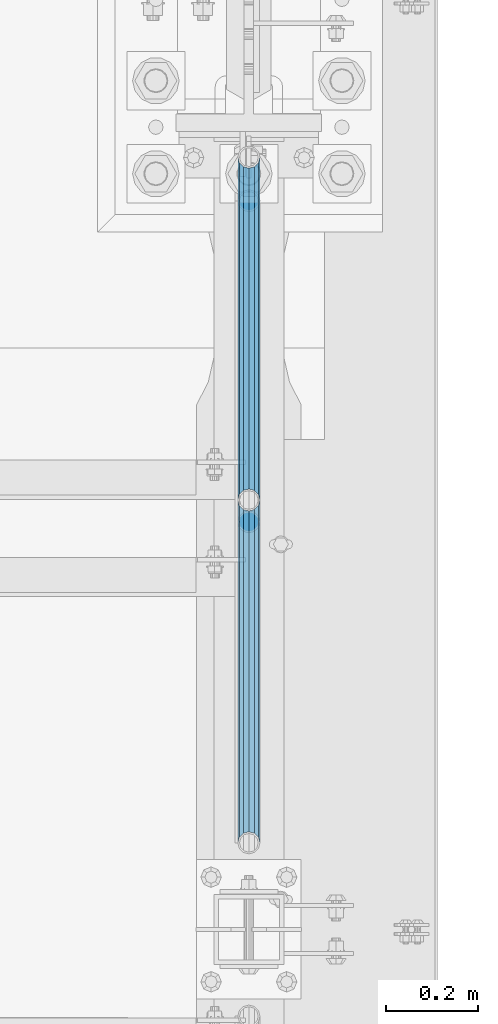
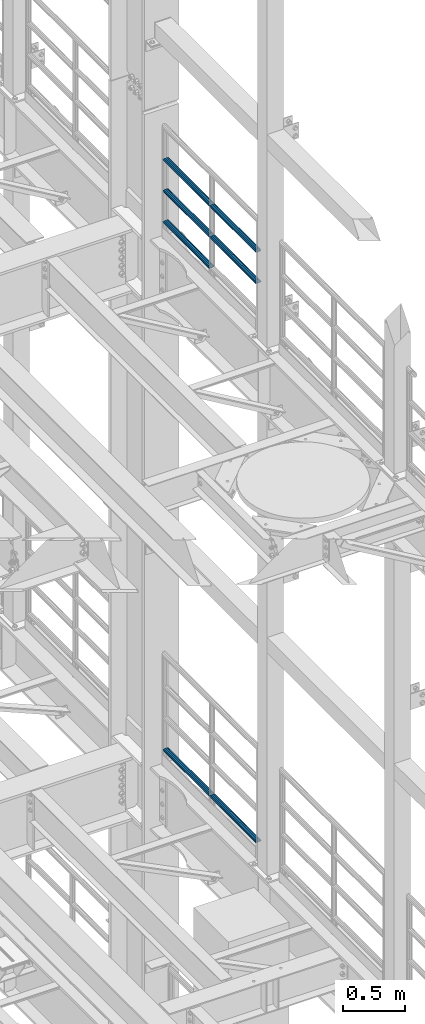
# One storey, part 1335 of 1876: 7 beams, 2 elements without a shape of their own.
"""IFC2X3 building model written with IfcOpenShell, lengths in millimetres."""

from ifc_helpers import new_model, si_unit, frame, origin_with_axes, place, context, subcontext, project, spatial, faceted_brep, material, type_object, element, aggregate, save


model = new_model("IFC2X3")

# Units and contexts
model_context = context("Model", 3, precision=1e-05, world=origin_with_axes())
body_context = subcontext(model_context, "Body", "Model", "MODEL_VIEW")
ifc_project = project(units=[si_unit("LENGTHUNIT", "METRE", prefix="MILLI"), si_unit("AREAUNIT", "SQUARE_METRE"), si_unit("VOLUMEUNIT", "CUBIC_METRE"), si_unit("MASSUNIT", "GRAM", prefix="KILO"), si_unit("TIMEUNIT", "SECOND"), si_unit("PLANEANGLEUNIT", "RADIAN"), si_unit("SOLIDANGLEUNIT", "STERADIAN"), si_unit("THERMODYNAMICTEMPERATUREUNIT", "DEGREE_CELSIUS"), si_unit("LUMINOUSINTENSITYUNIT", "LUMEN")], contexts=[model_context])

# Site, building, storey
site_placement = place(None, origin_with_axes())
site = spatial("IfcSite", under=ifc_project, at=site_placement, CompositionType="ELEMENT")
building_placement = place(site_placement, origin_with_axes())
building = spatial("IfcBuilding", under=site, at=building_placement, Name="Undefined", CompositionType="ELEMENT")
storey_placement = place(building_placement, origin_with_axes())
storey = spatial("IfcBuildingStorey", under=building, at=storey_placement, Name="Undefined", CompositionType="ELEMENT", Elevation=0.0)

# Assembly, beams
assembly_1_placement = place(storey_placement, origin_with_axes())
assembly_1 = element("IfcElementAssembly", 1, at=assembly_1_placement, inside=storey, Name="RAIL", AssemblyPlace="NOTDEFINED", PredefinedType="RIGID_FRAME")
ifc_material = material()
beam_type = type_object("IfcBeamType", Name="PIPE1-1/2SCH40", PredefinedType="NOTDEFINED")
beam_1_placement = place(assembly_1_placement, frame((7619.99999999999, 7275.195, 13471.525), z_axis=(0.0, 0.0, 1.0), x_axis=(0.0, -1.0, 0.0)))
beam_1 = element("IfcBeam", 2, at=beam_1_placement, type_object=beam_type, material=ifc_material, Name="RAIL", ObjectType="PIPE1-1/2SCH40", context=body_context, shape_type="Brep", body=[
    faceted_brep([(728.085307006683, -12.0649999999996, 20.8971929933177), (728.085307006683, -12.0649999999996, 15.8661214311796), (727.591878568821, -10.2235000000001, 17.7076214311819), (724.852500000002, 0.0, 20.4470000000001), (724.852500000002, 0.0, 24.130000000001), (727.591878568821, 10.2235000000001, 17.7076214311819), (728.085307006683, 12.0649999999996, 15.8661214311796), (728.085307006683, 12.0649999999996, 20.8971929933177), (748.982500000002, 24.1300000000001, 0.0), (736.917500000002, 20.8971929933186, 12.0649999999987), (736.917500000002, 20.8971929933186, -12.0649999999987), (733.727928437864, 17.7076214311801, 10.2235000000001), (736.467307006683, 20.4470000000001, 0.0), (733.727928437864, 17.7076214311801, -10.2235000000001), (728.085307006683, 12.0649999999996, -15.8661214311796), (728.085307006683, 12.0649999999996, -20.8971929933177), (727.591878568821, 10.2235000000001, -17.7076214311819), (724.852500000002, 0.0, -20.4470000000001), (724.852500000002, 0.0, -24.130000000001), (728.085307006683, -12.0649999999996, -15.8661214311796), (728.085307006683, -12.0649999999996, -20.8971929933177), (727.591878568821, -10.2235000000001, -17.7076214311819), (748.982500000002, -24.1300000000001, 0.0), (736.917500000002, -20.8971929933186, -12.0649999999987), (736.917500000002, -20.8971929933186, 12.0649999999987), (733.727928437864, -17.7076214311801, -10.2235000000001), (736.467307006683, -20.4470000000001, 0.0), (733.727928437864, -17.7076214311801, 10.2235000000001), (12.0650000000064, -20.8971929933177, -12.0649999999987), (20.8971929933249, -12.0650000000005, -20.8971929933177), (0.0, 24.1299999999992, 0.0), (12.0650000000064, 20.8971929933177, -12.0649999999987), (12.0650000000064, 20.8971929933177, 12.0649999999987), (20.8971929933249, 12.0650000000005, 20.8971929933177), (24.1300000000064, 0.0, 24.130000000001), (20.8971929933249, 12.0650000000005, -20.8971929933177), (24.1300000000063, 0.0, -24.130000000001), (24.1300000000063, 0.0, -20.4470000000001), (20.8971929933249, -12.0650000000005, -15.8661214311796), (21.3906214311868, -10.2235000000001, -17.7076214311819), (21.3906214311868, 10.2235000000001, -17.7076214311819), (20.8971929933249, 12.0650000000005, -15.8661214311796), (15.2545715621445, 17.7076214311801, -10.2235000000001), (12.5151929933249, 20.4470000000001, 0.0), (15.2545715621445, 17.7076214311801, 10.2235000000001), (20.8971929933249, 12.0650000000005, 15.8661214311796), (21.3906214311868, 10.2235000000001, 17.7076214311819), (24.1300000000064, 0.0, 20.4470000000001), (21.3906214311868, -10.2235000000001, 17.7076214311819), (20.8971929933249, -12.0650000000005, 15.8661214311796), (20.8971929933249, -12.0650000000005, 20.8971929933177), (12.0650000000064, -20.8971929933177, 12.0649999999987), (0.0, -24.1299999999992, 0.0), (15.2545715621445, -17.7076214311801, 10.2235000000001), (12.5151929933249, -20.4470000000001, 0.0), (15.2545715621445, -17.7076214311801, -10.2235000000001)], [[[0, 1, 2, 3, 4]], [[4, 3, 5, 6, 7]], [[8, 9, 10]], [[7, 6, 11, 12, 13, 14, 15, 10, 9]], [[16, 17, 18, 15, 14]], [[19, 20, 18, 17, 21]], [[22, 23, 24]], [[24, 23, 20, 19, 25, 26, 27, 1, 0]], [[28, 29, 20, 23]], [[30, 31, 32]], [[33, 34, 4, 7]], [[32, 33, 7, 9]], [[30, 32, 9, 8]], [[31, 30, 8, 10]], [[35, 31, 10, 15]], [[36, 35, 15, 18]], [[29, 36, 18, 20]], [[37, 36, 29, 38, 39]], [[40, 41, 35, 36, 37]], [[32, 31, 35, 41, 42, 43, 44, 45, 33]], [[33, 45, 46, 47, 34]], [[34, 47, 48, 49, 50]], [[34, 50, 0, 4]], [[50, 51, 24, 0]], [[51, 52, 22, 24]], [[52, 28, 23, 22]], [[51, 28, 52]], [[50, 49, 53, 54, 55, 38, 29, 28, 51]], [[55, 54, 26, 25]], [[21, 39, 38, 55, 25, 19]], [[37, 39, 21, 17]], [[40, 37, 17, 16]], [[42, 41, 40, 16, 14, 13]], [[43, 42, 13, 12]], [[44, 43, 12, 11]], [[5, 46, 45, 44, 11, 6]], [[47, 46, 5, 3]], [[48, 47, 3, 2]], [[53, 49, 48, 2, 1, 27]], [[54, 53, 27, 26]]]),
])
beam_2_placement = place(assembly_1_placement, frame((7620.0, 5777.23, 13776.325), z_axis=(0.0, 0.0, -1.0), x_axis=(0.0, 1.0, 0.0)))
beam_2 = element("IfcBeam", 3, at=beam_2_placement, type_object=beam_type, material=ifc_material, Name="RAIL", ObjectType="PIPE1-1/2SCH40", context=body_context, shape_type="Brep", body=[
    faceted_brep([(0.0, 24.1299999999992, 0.0), (12.0650000000064, 20.8971929933177, -12.0649999999987), (12.0650000000064, 20.8971929933177, 12.0649999999987), (12.0650000000064, -20.8971929933177, 12.0649999999987), (12.0650000000064, -20.8971929933177, -12.0649999999987), (0.0, -24.1299999999992, 0.0), (20.8971929933249, -12.0650000000005, 20.8971929933177), (20.8971929933249, -12.0650000000005, 15.8661214311796), (15.2545715621445, -17.7076214311801, 10.2235000000001), (12.5151929933249, -20.4470000000001, 0.0), (15.2545715621445, -17.7076214311801, -10.2235000000001), (20.8971929933249, -12.0650000000005, -15.8661214311796), (20.8971929933249, -12.0650000000005, -20.8971929933177), (24.1300000000063, 0.0, -20.4470000000001), (24.1300000000063, 0.0, -24.130000000001), (21.3906214311868, -10.2235000000001, -17.7076214311819), (21.3906214311868, 10.2235000000001, -17.7076214311819), (20.8971929933249, 12.0650000000005, -15.8661214311796), (20.8971929933249, 12.0650000000005, -20.8971929933177), (15.2545715621445, 17.7076214311801, -10.2235000000001), (12.5151929933249, 20.4470000000001, 0.0), (15.2545715621445, 17.7076214311801, 10.2235000000001), (20.8971929933249, 12.0650000000005, 15.8661214311796), (20.8971929933249, 12.0650000000005, 20.8971929933177), (21.3906214311868, 10.2235000000001, 17.7076214311819), (24.1300000000064, 0.0, 20.4470000000001), (24.1300000000064, 0.0, 24.130000000001), (21.3906214311868, -10.2235000000001, 17.7076214311819), (748.982500000002, 24.1300000000001, 0.0), (736.917500000002, 20.8971929933186, -12.0649999999987), (728.085307006683, 12.0649999999996, -20.8971929933177), (748.982500000002, -24.1300000000001, 0.0), (736.917500000002, -20.8971929933186, -12.0649999999987), (736.917500000002, -20.8971929933186, 12.0649999999987), (728.085307006683, -12.0649999999996, 20.8971929933177), (728.085307006683, -12.0649999999996, -20.8971929933177), (724.852500000002, 0.0, -24.130000000001), (727.591878568821, 10.2235000000001, -17.7076214311819), (724.852500000002, 0.0, -20.4470000000001), (728.085307006683, 12.0649999999996, -15.8661214311796), (728.085307006683, -12.0649999999996, -15.8661214311796), (727.591878568821, -10.2235000000001, -17.7076214311819), (733.727928437864, -17.7076214311801, -10.2235000000001), (736.467307006683, -20.4470000000001, 0.0), (733.727928437864, -17.7076214311801, 10.2235000000001), (728.085307006683, -12.0649999999996, 15.8661214311796), (727.591878568821, -10.2235000000001, 17.7076214311819), (724.852500000002, 0.0, 20.4470000000001), (724.852500000002, 0.0, 24.130000000001), (728.085307006683, 12.0649999999996, 20.8971929933177), (736.917500000002, 20.8971929933186, 12.0649999999987), (728.085307006683, 12.0649999999996, 15.8661214311796), (733.727928437864, 17.7076214311801, 10.2235000000001), (736.467307006683, 20.4470000000001, 0.0), (733.727928437864, 17.7076214311801, -10.2235000000001), (727.591878568821, 10.2235000000001, 17.7076214311819)], [[[0, 1, 2]], [[3, 4, 5]], [[6, 7, 8, 9, 10, 11, 12, 4, 3]], [[13, 14, 12, 11, 15]], [[16, 17, 18, 14, 13]], [[2, 1, 18, 17, 19, 20, 21, 22, 23]], [[23, 22, 24, 25, 26]], [[26, 25, 27, 7, 6]], [[1, 0, 28, 29]], [[18, 1, 29, 30]], [[31, 32, 33]], [[6, 3, 33, 34]], [[3, 5, 31, 33]], [[5, 4, 32, 31]], [[4, 12, 35, 32]], [[12, 14, 36, 35]], [[14, 18, 30, 36]], [[37, 38, 36, 30, 39]], [[40, 35, 36, 38, 41]], [[33, 32, 35, 40, 42, 43, 44, 45, 34]], [[34, 45, 46, 47, 48]], [[26, 6, 34, 48]], [[2, 23, 49, 50]], [[23, 26, 48, 49]], [[0, 2, 50, 28]], [[28, 50, 29]], [[49, 51, 52, 53, 54, 39, 30, 29, 50]], [[48, 47, 55, 51, 49]], [[25, 24, 55, 47]], [[55, 24, 22, 21, 52, 51]], [[21, 20, 53, 52]], [[20, 19, 54, 53]], [[19, 17, 16, 37, 39, 54]], [[16, 13, 38, 37]], [[13, 15, 41, 38]], [[41, 15, 11, 10, 42, 40]], [[10, 9, 43, 42]], [[9, 8, 44, 43]], [[8, 7, 27, 46, 45, 44]], [[27, 25, 47, 46]]]),
])
beam_3_placement = place(assembly_1_placement, frame((7620.0, 6526.2125, 13776.325), z_axis=(0.0, 0.0, -1.0), x_axis=(0.0, 1.0, 0.0)))
beam_3 = element("IfcBeam", 4, at=beam_3_placement, type_object=beam_type, material=ifc_material, Name="RAIL", ObjectType="PIPE1-1/2SCH40", context=body_context, shape_type="Brep", body=[
    faceted_brep([(0.0, 24.1299999999992, 0.0), (12.0650000000064, 20.8971929933177, -12.0649999999987), (12.0650000000064, 20.8971929933177, 12.0649999999987), (12.0650000000064, -20.8971929933177, 12.0649999999987), (12.0650000000064, -20.8971929933177, -12.0649999999987), (0.0, -24.1299999999992, 0.0), (20.8971929933249, -12.0650000000005, 20.8971929933177), (20.8971929933249, -12.0650000000005, 15.8661214311796), (15.2545715621445, -17.7076214311801, 10.2235000000001), (12.5151929933249, -20.4470000000001, 0.0), (15.2545715621445, -17.7076214311801, -10.2235000000001), (20.8971929933249, -12.0650000000005, -15.8661214311796), (20.8971929933249, -12.0650000000005, -20.8971929933177), (24.1300000000063, 0.0, -20.4470000000001), (24.1300000000063, 0.0, -24.130000000001), (21.3906214311868, -10.2235000000001, -17.7076214311819), (21.3906214311868, 10.2235000000001, -17.7076214311819), (20.8971929933249, 12.0650000000005, -15.8661214311796), (20.8971929933249, 12.0650000000005, -20.8971929933177), (15.2545715621445, 17.7076214311801, -10.2235000000001), (12.5151929933249, 20.4470000000001, 0.0), (15.2545715621445, 17.7076214311801, 10.2235000000001), (20.8971929933249, 12.0650000000005, 15.8661214311796), (20.8971929933249, 12.0650000000005, 20.8971929933177), (21.3906214311868, 10.2235000000001, 17.7076214311819), (24.1300000000064, 0.0, 20.4470000000001), (24.1300000000064, 0.0, 24.130000000001), (21.3906214311868, -10.2235000000001, 17.7076214311819), (748.982500000002, 24.1300000000001, 0.0), (736.917500000002, 20.8971929933186, -12.0649999999987), (728.085307006683, 12.0649999999996, -20.8971929933177), (748.982500000002, -24.1300000000001, 0.0), (736.917500000002, -20.8971929933186, -12.0649999999987), (736.917500000002, -20.8971929933186, 12.0649999999987), (728.085307006683, -12.0649999999996, 20.8971929933177), (728.085307006683, -12.0649999999996, -20.8971929933177), (724.852500000002, 0.0, -24.130000000001), (727.591878568821, 10.2235000000001, -17.7076214311819), (724.852500000002, 0.0, -20.4470000000001), (728.085307006683, 12.0649999999996, -15.8661214311796), (728.085307006683, -12.0649999999996, -15.8661214311796), (727.591878568821, -10.2235000000001, -17.7076214311819), (733.727928437864, -17.7076214311801, -10.2235000000001), (736.467307006683, -20.4470000000001, 0.0), (733.727928437864, -17.7076214311801, 10.2235000000001), (728.085307006683, -12.0649999999996, 15.8661214311796), (727.591878568821, -10.2235000000001, 17.7076214311819), (724.852500000002, 0.0, 20.4470000000001), (724.852500000002, 0.0, 24.130000000001), (728.085307006683, 12.0649999999996, 20.8971929933177), (736.917500000002, 20.8971929933186, 12.0649999999987), (728.085307006683, 12.0649999999996, 15.8661214311796), (733.727928437864, 17.7076214311801, 10.2235000000001), (736.467307006683, 20.4470000000001, 0.0), (733.727928437864, 17.7076214311801, -10.2235000000001), (727.591878568821, 10.2235000000001, 17.7076214311819)], [[[0, 1, 2]], [[3, 4, 5]], [[6, 7, 8, 9, 10, 11, 12, 4, 3]], [[13, 14, 12, 11, 15]], [[16, 17, 18, 14, 13]], [[2, 1, 18, 17, 19, 20, 21, 22, 23]], [[23, 22, 24, 25, 26]], [[26, 25, 27, 7, 6]], [[1, 0, 28, 29]], [[18, 1, 29, 30]], [[31, 32, 33]], [[6, 3, 33, 34]], [[3, 5, 31, 33]], [[5, 4, 32, 31]], [[4, 12, 35, 32]], [[12, 14, 36, 35]], [[14, 18, 30, 36]], [[37, 38, 36, 30, 39]], [[40, 35, 36, 38, 41]], [[33, 32, 35, 40, 42, 43, 44, 45, 34]], [[34, 45, 46, 47, 48]], [[26, 6, 34, 48]], [[2, 23, 49, 50]], [[23, 26, 48, 49]], [[0, 2, 50, 28]], [[28, 50, 29]], [[49, 51, 52, 53, 54, 39, 30, 29, 50]], [[48, 47, 55, 51, 49]], [[25, 24, 55, 47]], [[55, 24, 22, 21, 52, 51]], [[21, 20, 53, 52]], [[20, 19, 54, 53]], [[19, 17, 16, 37, 39, 54]], [[16, 13, 38, 37]], [[13, 15, 41, 38]], [[41, 15, 11, 10, 42, 40]], [[10, 9, 43, 42]], [[9, 8, 44, 43]], [[8, 7, 27, 46, 45, 44]], [[27, 25, 47, 46]]]),
])
beam_4_placement = place(assembly_1_placement, frame((7620.0, 5777.23, 14081.125), z_axis=(0.0, 0.0, -1.0), x_axis=(0.0, 1.0, 0.0)))
beam_4 = element("IfcBeam", 5, at=beam_4_placement, type_object=beam_type, material=ifc_material, Name="RAIL", ObjectType="PIPE1-1/2SCH40", context=body_context, shape_type="Brep", body=[
    faceted_brep([(0.0, 24.1299999999992, 0.0), (12.0650000000064, 20.8971929933177, -12.0649999999987), (12.0650000000064, 20.8971929933177, 12.0649999999987), (12.0650000000064, -20.8971929933177, 12.0649999999987), (12.0650000000064, -20.8971929933177, -12.0649999999987), (0.0, -24.1299999999992, 0.0), (20.8971929933249, -12.0650000000005, 20.8971929933177), (20.8971929933249, -12.0650000000005, 15.8661214311796), (15.2545715621445, -17.7076214311801, 10.2235000000001), (12.5151929933249, -20.4470000000001, 0.0), (15.2545715621445, -17.7076214311801, -10.2235000000001), (20.8971929933249, -12.0650000000005, -15.8661214311796), (20.8971929933249, -12.0650000000005, -20.8971929933177), (24.1300000000063, 0.0, -20.4470000000001), (24.1300000000063, 0.0, -24.130000000001), (21.3906214311868, -10.2235000000001, -17.7076214311819), (21.3906214311868, 10.2235000000001, -17.7076214311819), (20.8971929933249, 12.0650000000005, -15.8661214311796), (20.8971929933249, 12.0650000000005, -20.8971929933177), (15.2545715621445, 17.7076214311801, -10.2235000000001), (12.5151929933249, 20.4470000000001, 0.0), (15.2545715621445, 17.7076214311801, 10.2235000000001), (20.8971929933249, 12.0650000000005, 15.8661214311796), (20.8971929933249, 12.0650000000005, 20.8971929933177), (21.3906214311868, 10.2235000000001, 17.7076214311819), (24.1300000000064, 0.0, 20.4470000000001), (24.1300000000064, 0.0, 24.130000000001), (21.3906214311868, -10.2235000000001, 17.7076214311819), (748.982500000002, 24.1300000000001, 0.0), (736.917500000002, 20.8971929933186, -12.0649999999987), (728.085307006683, 12.0649999999996, -20.8971929933177), (748.982500000002, -24.1300000000001, 0.0), (736.917500000002, -20.8971929933186, -12.0649999999987), (736.917500000002, -20.8971929933186, 12.0649999999987), (728.085307006683, -12.0649999999996, 20.8971929933177), (728.085307006683, -12.0649999999996, -20.8971929933177), (724.852500000002, 0.0, -24.130000000001), (727.591878568821, 10.2235000000001, -17.7076214311819), (724.852500000002, 0.0, -20.4470000000001), (728.085307006683, 12.0649999999996, -15.8661214311796), (728.085307006683, -12.0649999999996, -15.8661214311796), (727.591878568821, -10.2235000000001, -17.7076214311819), (733.727928437864, -17.7076214311801, -10.2235000000001), (736.467307006683, -20.4470000000001, 0.0), (733.727928437864, -17.7076214311801, 10.2235000000001), (728.085307006683, -12.0649999999996, 15.8661214311796), (727.591878568821, -10.2235000000001, 17.7076214311819), (724.852500000002, 0.0, 20.4470000000001), (724.852500000002, 0.0, 24.130000000001), (728.085307006683, 12.0649999999996, 20.8971929933177), (736.917500000002, 20.8971929933186, 12.0649999999987), (728.085307006683, 12.0649999999996, 15.8661214311796), (733.727928437864, 17.7076214311801, 10.2235000000001), (736.467307006683, 20.4470000000001, 0.0), (733.727928437864, 17.7076214311801, -10.2235000000001), (727.591878568821, 10.2235000000001, 17.7076214311819)], [[[0, 1, 2]], [[3, 4, 5]], [[6, 7, 8, 9, 10, 11, 12, 4, 3]], [[13, 14, 12, 11, 15]], [[16, 17, 18, 14, 13]], [[2, 1, 18, 17, 19, 20, 21, 22, 23]], [[23, 22, 24, 25, 26]], [[26, 25, 27, 7, 6]], [[1, 0, 28, 29]], [[18, 1, 29, 30]], [[31, 32, 33]], [[6, 3, 33, 34]], [[3, 5, 31, 33]], [[5, 4, 32, 31]], [[4, 12, 35, 32]], [[12, 14, 36, 35]], [[14, 18, 30, 36]], [[37, 38, 36, 30, 39]], [[40, 35, 36, 38, 41]], [[33, 32, 35, 40, 42, 43, 44, 45, 34]], [[34, 45, 46, 47, 48]], [[26, 6, 34, 48]], [[2, 23, 49, 50]], [[23, 26, 48, 49]], [[0, 2, 50, 28]], [[28, 50, 29]], [[49, 51, 52, 53, 54, 39, 30, 29, 50]], [[48, 47, 55, 51, 49]], [[25, 24, 55, 47]], [[55, 24, 22, 21, 52, 51]], [[21, 20, 53, 52]], [[20, 19, 54, 53]], [[19, 17, 16, 37, 39, 54]], [[16, 13, 38, 37]], [[13, 15, 41, 38]], [[41, 15, 11, 10, 42, 40]], [[10, 9, 43, 42]], [[9, 8, 44, 43]], [[8, 7, 27, 46, 45, 44]], [[27, 25, 47, 46]]]),
])
beam_5_placement = place(assembly_1_placement, frame((7620.0, 6526.2125, 14081.125), z_axis=(0.0, 0.0, -1.0), x_axis=(0.0, 1.0, 0.0)))
beam_5 = element("IfcBeam", 6, at=beam_5_placement, type_object=beam_type, material=ifc_material, Name="RAIL", ObjectType="PIPE1-1/2SCH40", context=body_context, shape_type="Brep", body=[
    faceted_brep([(0.0, 24.1299999999992, 0.0), (12.0650000000064, 20.8971929933177, -12.0649999999987), (12.0650000000064, 20.8971929933177, 12.0649999999987), (12.0650000000064, -20.8971929933177, 12.0649999999987), (12.0650000000064, -20.8971929933177, -12.0649999999987), (0.0, -24.1299999999992, 0.0), (20.8971929933249, -12.0650000000005, 20.8971929933177), (20.8971929933249, -12.0650000000005, 15.8661214311796), (15.2545715621445, -17.7076214311801, 10.2235000000001), (12.5151929933249, -20.4470000000001, 0.0), (15.2545715621445, -17.7076214311801, -10.2235000000001), (20.8971929933249, -12.0650000000005, -15.8661214311796), (20.8971929933249, -12.0650000000005, -20.8971929933177), (24.1300000000063, 0.0, -20.4470000000001), (24.1300000000063, 0.0, -24.130000000001), (21.3906214311868, -10.2235000000001, -17.7076214311819), (21.3906214311868, 10.2235000000001, -17.7076214311819), (20.8971929933249, 12.0650000000005, -15.8661214311796), (20.8971929933249, 12.0650000000005, -20.8971929933177), (15.2545715621445, 17.7076214311801, -10.2235000000001), (12.5151929933249, 20.4470000000001, 0.0), (15.2545715621445, 17.7076214311801, 10.2235000000001), (20.8971929933249, 12.0650000000005, 15.8661214311796), (20.8971929933249, 12.0650000000005, 20.8971929933177), (21.3906214311868, 10.2235000000001, 17.7076214311819), (24.1300000000064, 0.0, 20.4470000000001), (24.1300000000064, 0.0, 24.130000000001), (21.3906214311868, -10.2235000000001, 17.7076214311819), (748.982500000002, 24.1300000000001, 0.0), (736.917500000002, 20.8971929933186, -12.0649999999987), (728.085307006683, 12.0649999999996, -20.8971929933177), (748.982500000002, -24.1300000000001, 0.0), (736.917500000002, -20.8971929933186, -12.0649999999987), (736.917500000002, -20.8971929933186, 12.0649999999987), (728.085307006683, -12.0649999999996, 20.8971929933177), (728.085307006683, -12.0649999999996, -20.8971929933177), (724.852500000002, 0.0, -24.130000000001), (727.591878568821, 10.2235000000001, -17.7076214311819), (724.852500000002, 0.0, -20.4470000000001), (728.085307006683, 12.0649999999996, -15.8661214311796), (728.085307006683, -12.0649999999996, -15.8661214311796), (727.591878568821, -10.2235000000001, -17.7076214311819), (733.727928437864, -17.7076214311801, -10.2235000000001), (736.467307006683, -20.4470000000001, 0.0), (733.727928437864, -17.7076214311801, 10.2235000000001), (728.085307006683, -12.0649999999996, 15.8661214311796), (727.591878568821, -10.2235000000001, 17.7076214311819), (724.852500000002, 0.0, 20.4470000000001), (724.852500000002, 0.0, 24.130000000001), (728.085307006683, 12.0649999999996, 20.8971929933177), (736.917500000002, 20.8971929933186, 12.0649999999987), (728.085307006683, 12.0649999999996, 15.8661214311796), (733.727928437864, 17.7076214311801, 10.2235000000001), (736.467307006683, 20.4470000000001, 0.0), (733.727928437864, 17.7076214311801, -10.2235000000001), (727.591878568821, 10.2235000000001, 17.7076214311819)], [[[0, 1, 2]], [[3, 4, 5]], [[6, 7, 8, 9, 10, 11, 12, 4, 3]], [[13, 14, 12, 11, 15]], [[16, 17, 18, 14, 13]], [[2, 1, 18, 17, 19, 20, 21, 22, 23]], [[23, 22, 24, 25, 26]], [[26, 25, 27, 7, 6]], [[1, 0, 28, 29]], [[18, 1, 29, 30]], [[31, 32, 33]], [[6, 3, 33, 34]], [[3, 5, 31, 33]], [[5, 4, 32, 31]], [[4, 12, 35, 32]], [[12, 14, 36, 35]], [[14, 18, 30, 36]], [[37, 38, 36, 30, 39]], [[40, 35, 36, 38, 41]], [[33, 32, 35, 40, 42, 43, 44, 45, 34]], [[34, 45, 46, 47, 48]], [[26, 6, 34, 48]], [[2, 23, 49, 50]], [[23, 26, 48, 49]], [[0, 2, 50, 28]], [[28, 50, 29]], [[49, 51, 52, 53, 54, 39, 30, 29, 50]], [[48, 47, 55, 51, 49]], [[25, 24, 55, 47]], [[55, 24, 22, 21, 52, 51]], [[21, 20, 53, 52]], [[20, 19, 54, 53]], [[19, 17, 16, 37, 39, 54]], [[16, 13, 38, 37]], [[13, 15, 41, 38]], [[41, 15, 11, 10, 42, 40]], [[10, 9, 43, 42]], [[9, 8, 44, 43]], [[8, 7, 27, 46, 45, 44]], [[27, 25, 47, 46]]]),
])
aggregate(assembly_1, [beam_1, beam_2, beam_3, beam_4, beam_5])

assembly_2_placement = place(storey_placement, origin_with_axes())
assembly_2 = element("IfcElementAssembly", 7, at=assembly_2_placement, inside=storey, Name="RAIL", AssemblyPlace="NOTDEFINED", PredefinedType="RIGID_FRAME")
beam_6_placement = place(assembly_2_placement, frame((7620.0, 6526.2125, 8315.325), z_axis=(0.0, 0.0, 1.0), x_axis=(0.0, -1.0, 0.0)))
beam_6 = element("IfcBeam", 8, at=beam_6_placement, type_object=beam_type, material=ifc_material, Name="RAIL", ObjectType="PIPE1-1/2SCH40", context=body_context, shape_type="Brep", body=[
    faceted_brep([(728.085307006683, -12.0649999999996, 20.8971929933177), (728.085307006683, -12.0649999999996, 15.8661214311796), (727.591878568821, -10.2235000000001, 17.7076214311819), (724.852500000002, 0.0, 20.4470000000001), (724.852500000002, 0.0, 24.130000000001), (727.591878568821, 10.2235000000001, 17.7076214311819), (728.085307006683, 12.0649999999996, 15.8661214311796), (728.085307006683, 12.0649999999996, 20.8971929933177), (748.982500000002, 24.1300000000001, 0.0), (736.917500000002, 20.8971929933186, 12.0649999999987), (736.917500000002, 20.8971929933186, -12.0649999999987), (733.727928437864, 17.7076214311801, 10.2235000000001), (736.467307006683, 20.4470000000001, 0.0), (733.727928437864, 17.7076214311801, -10.2235000000001), (728.085307006683, 12.0649999999996, -15.8661214311796), (728.085307006683, 12.0649999999996, -20.8971929933177), (727.591878568821, 10.2235000000001, -17.7076214311819), (724.852500000002, 0.0, -20.4470000000001), (724.852500000002, 0.0, -24.130000000001), (728.085307006683, -12.0649999999996, -15.8661214311796), (728.085307006683, -12.0649999999996, -20.8971929933177), (727.591878568821, -10.2235000000001, -17.7076214311819), (748.982500000002, -24.1300000000001, 0.0), (736.917500000002, -20.8971929933186, -12.0649999999987), (736.917500000002, -20.8971929933186, 12.0649999999987), (733.727928437864, -17.7076214311801, -10.2235000000001), (736.467307006683, -20.4470000000001, 0.0), (733.727928437864, -17.7076214311801, 10.2235000000001), (12.0650000000064, -20.8971929933177, -12.0649999999987), (20.8971929933249, -12.0650000000005, -20.8971929933177), (0.0, 24.1299999999992, 0.0), (12.0650000000064, 20.8971929933177, -12.0649999999987), (12.0650000000064, 20.8971929933177, 12.0649999999987), (20.8971929933249, 12.0650000000005, 20.8971929933177), (24.1300000000064, 0.0, 24.130000000001), (20.8971929933249, 12.0650000000005, -20.8971929933177), (24.1300000000063, 0.0, -24.130000000001), (24.1300000000063, 0.0, -20.4470000000001), (20.8971929933249, -12.0650000000005, -15.8661214311796), (21.3906214311868, -10.2235000000001, -17.7076214311819), (21.3906214311868, 10.2235000000001, -17.7076214311819), (20.8971929933249, 12.0650000000005, -15.8661214311796), (15.2545715621445, 17.7076214311801, -10.2235000000001), (12.5151929933249, 20.4470000000001, 0.0), (15.2545715621445, 17.7076214311801, 10.2235000000001), (20.8971929933249, 12.0650000000005, 15.8661214311796), (21.3906214311868, 10.2235000000001, 17.7076214311819), (24.1300000000064, 0.0, 20.4470000000001), (21.3906214311868, -10.2235000000001, 17.7076214311819), (20.8971929933249, -12.0650000000005, 15.8661214311796), (20.8971929933249, -12.0650000000005, 20.8971929933177), (12.0650000000064, -20.8971929933177, 12.0649999999987), (0.0, -24.1299999999992, 0.0), (15.2545715621445, -17.7076214311801, 10.2235000000001), (12.5151929933249, -20.4470000000001, 0.0), (15.2545715621445, -17.7076214311801, -10.2235000000001)], [[[0, 1, 2, 3, 4]], [[4, 3, 5, 6, 7]], [[8, 9, 10]], [[7, 6, 11, 12, 13, 14, 15, 10, 9]], [[16, 17, 18, 15, 14]], [[19, 20, 18, 17, 21]], [[22, 23, 24]], [[24, 23, 20, 19, 25, 26, 27, 1, 0]], [[28, 29, 20, 23]], [[30, 31, 32]], [[33, 34, 4, 7]], [[32, 33, 7, 9]], [[30, 32, 9, 8]], [[31, 30, 8, 10]], [[35, 31, 10, 15]], [[36, 35, 15, 18]], [[29, 36, 18, 20]], [[37, 36, 29, 38, 39]], [[40, 41, 35, 36, 37]], [[32, 31, 35, 41, 42, 43, 44, 45, 33]], [[33, 45, 46, 47, 34]], [[34, 47, 48, 49, 50]], [[34, 50, 0, 4]], [[50, 51, 24, 0]], [[51, 52, 22, 24]], [[52, 28, 23, 22]], [[51, 28, 52]], [[50, 49, 53, 54, 55, 38, 29, 28, 51]], [[55, 54, 26, 25]], [[21, 39, 38, 55, 25, 19]], [[37, 39, 21, 17]], [[40, 37, 17, 16]], [[42, 41, 40, 16, 14, 13]], [[43, 42, 13, 12]], [[44, 43, 12, 11]], [[5, 46, 45, 44, 11, 6]], [[47, 46, 5, 3]], [[48, 47, 3, 2]], [[53, 49, 48, 2, 1, 27]], [[54, 53, 27, 26]]]),
])
beam_7_placement = place(assembly_2_placement, frame((7619.99999999999, 7275.195, 8315.325), z_axis=(0.0, 0.0, 1.0), x_axis=(0.0, -1.0, 0.0)))
beam_7 = element("IfcBeam", 9, at=beam_7_placement, type_object=beam_type, material=ifc_material, Name="RAIL", ObjectType="PIPE1-1/2SCH40", context=body_context, shape_type="Brep", body=[
    faceted_brep([(728.085307006683, -12.0649999999996, 20.8971929933177), (728.085307006683, -12.0649999999996, 15.8661214311796), (727.591878568821, -10.2235000000001, 17.7076214311819), (724.852500000002, 0.0, 20.4470000000001), (724.852500000002, 0.0, 24.130000000001), (727.591878568821, 10.2235000000001, 17.7076214311819), (728.085307006683, 12.0649999999996, 15.8661214311796), (728.085307006683, 12.0649999999996, 20.8971929933177), (748.982500000002, 24.1300000000001, 0.0), (736.917500000002, 20.8971929933186, 12.0649999999987), (736.917500000002, 20.8971929933186, -12.0649999999987), (733.727928437864, 17.7076214311801, 10.2235000000001), (736.467307006683, 20.4470000000001, 0.0), (733.727928437864, 17.7076214311801, -10.2235000000001), (728.085307006683, 12.0649999999996, -15.8661214311796), (728.085307006683, 12.0649999999996, -20.8971929933177), (727.591878568821, 10.2235000000001, -17.7076214311819), (724.852500000002, 0.0, -20.4470000000001), (724.852500000002, 0.0, -24.130000000001), (728.085307006683, -12.0649999999996, -15.8661214311796), (728.085307006683, -12.0649999999996, -20.8971929933177), (727.591878568821, -10.2235000000001, -17.7076214311819), (748.982500000002, -24.1300000000001, 0.0), (736.917500000002, -20.8971929933186, -12.0649999999987), (736.917500000002, -20.8971929933186, 12.0649999999987), (733.727928437864, -17.7076214311801, -10.2235000000001), (736.467307006683, -20.4470000000001, 0.0), (733.727928437864, -17.7076214311801, 10.2235000000001), (12.0650000000064, -20.8971929933177, -12.0649999999987), (20.8971929933249, -12.0650000000005, -20.8971929933177), (0.0, 24.1299999999992, 0.0), (12.0650000000064, 20.8971929933177, -12.0649999999987), (12.0650000000064, 20.8971929933177, 12.0649999999987), (20.8971929933249, 12.0650000000005, 20.8971929933177), (24.1300000000064, 0.0, 24.130000000001), (20.8971929933249, 12.0650000000005, -20.8971929933177), (24.1300000000063, 0.0, -24.130000000001), (24.1300000000063, 0.0, -20.4470000000001), (20.8971929933249, -12.0650000000005, -15.8661214311796), (21.3906214311868, -10.2235000000001, -17.7076214311819), (21.3906214311868, 10.2235000000001, -17.7076214311819), (20.8971929933249, 12.0650000000005, -15.8661214311796), (15.2545715621445, 17.7076214311801, -10.2235000000001), (12.5151929933249, 20.4470000000001, 0.0), (15.2545715621445, 17.7076214311801, 10.2235000000001), (20.8971929933249, 12.0650000000005, 15.8661214311796), (21.3906214311868, 10.2235000000001, 17.7076214311819), (24.1300000000064, 0.0, 20.4470000000001), (21.3906214311868, -10.2235000000001, 17.7076214311819), (20.8971929933249, -12.0650000000005, 15.8661214311796), (20.8971929933249, -12.0650000000005, 20.8971929933177), (12.0650000000064, -20.8971929933177, 12.0649999999987), (0.0, -24.1299999999992, 0.0), (15.2545715621445, -17.7076214311801, 10.2235000000001), (12.5151929933249, -20.4470000000001, 0.0), (15.2545715621445, -17.7076214311801, -10.2235000000001)], [[[0, 1, 2, 3, 4]], [[4, 3, 5, 6, 7]], [[8, 9, 10]], [[7, 6, 11, 12, 13, 14, 15, 10, 9]], [[16, 17, 18, 15, 14]], [[19, 20, 18, 17, 21]], [[22, 23, 24]], [[24, 23, 20, 19, 25, 26, 27, 1, 0]], [[28, 29, 20, 23]], [[30, 31, 32]], [[33, 34, 4, 7]], [[32, 33, 7, 9]], [[30, 32, 9, 8]], [[31, 30, 8, 10]], [[35, 31, 10, 15]], [[36, 35, 15, 18]], [[29, 36, 18, 20]], [[37, 36, 29, 38, 39]], [[40, 41, 35, 36, 37]], [[32, 31, 35, 41, 42, 43, 44, 45, 33]], [[33, 45, 46, 47, 34]], [[34, 47, 48, 49, 50]], [[34, 50, 0, 4]], [[50, 51, 24, 0]], [[51, 52, 22, 24]], [[52, 28, 23, 22]], [[51, 28, 52]], [[50, 49, 53, 54, 55, 38, 29, 28, 51]], [[55, 54, 26, 25]], [[21, 39, 38, 55, 25, 19]], [[37, 39, 21, 17]], [[40, 37, 17, 16]], [[42, 41, 40, 16, 14, 13]], [[43, 42, 13, 12]], [[44, 43, 12, 11]], [[5, 46, 45, 44, 11, 6]], [[47, 46, 5, 3]], [[48, 47, 3, 2]], [[53, 49, 48, 2, 1, 27]], [[54, 53, 27, 26]]]),
])
aggregate(assembly_2, [beam_6, beam_7])

save(model, "model.ifc")
